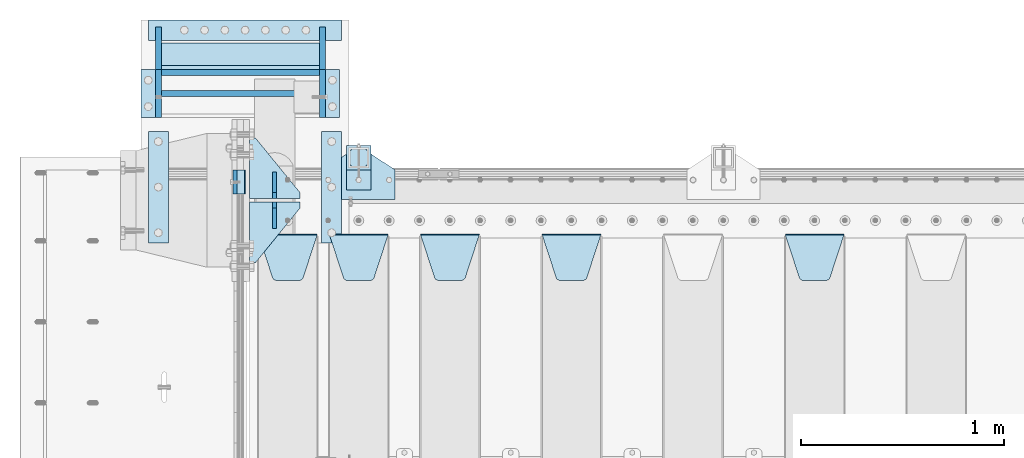
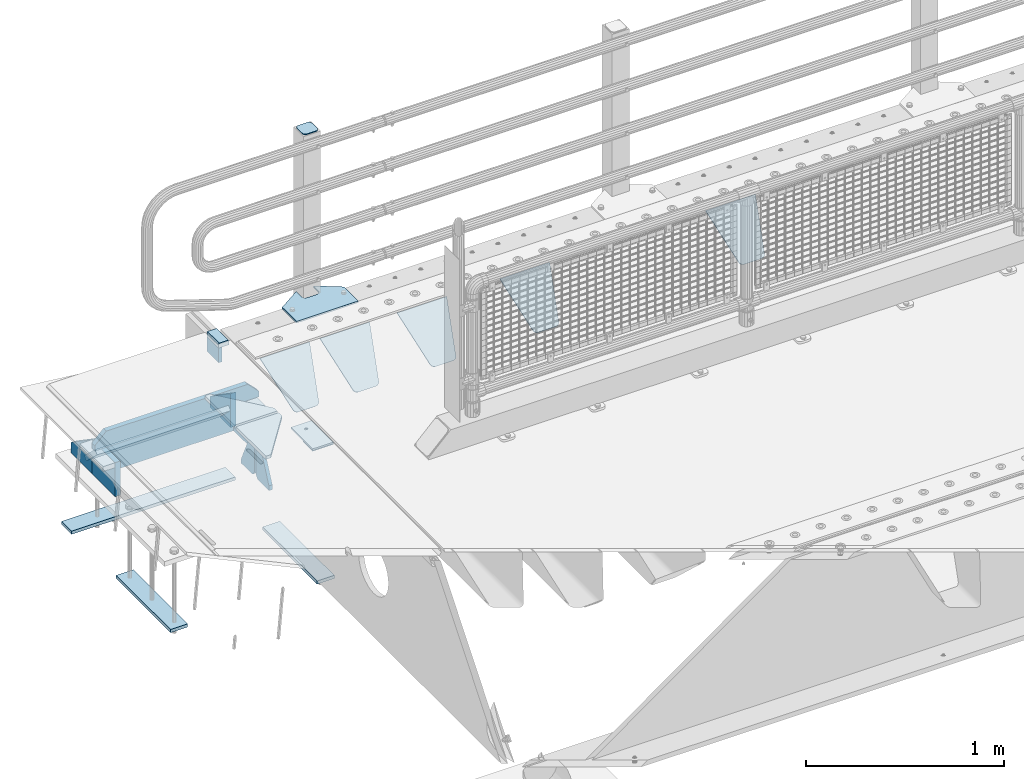
# One storey, part 171 of 208: 27 plates.
"""IFC2X3 building model written with IfcOpenShell, lengths in millimetres."""

import ifcopenshell
import ifcopenshell.guid

model = None  # the IFC model being written
_history = None  # IfcOwnerHistory: only IFC2X3 demands one
_inside = {}  # id of a spatial element -> (the spatial element, [elements in it])
_under = {}  # id of a project, library or spatial element -> (it, [spatial elements below it])
_declared = {}  # id of a project -> (the project, [libraries it declares])
_typed = {}  # id of a type object -> (the type object, [elements of that type])
_made_of = {}  # id of a material, layer set ... -> (it, [elements and type objects made of it])


def new_model(schema):
    """Start an empty IFC model of exactly this schema.

    Asked for "IFC4X3", IfcOpenShell would pick the latest addendum, in which some entities
    have other attributes; the version numbers below select the first issue.
    IFC2X3 requires an IfcOwnerHistory on every rooted entity: one is made here for all.
    """
    global model, _history
    if schema == "IFC4X3":
        model = ifcopenshell.file(schema_version=(4, 3, 0, 0))
    else:
        model = ifcopenshell.file(schema=schema)
    _inside.clear()
    _under.clear()
    _declared.clear()
    _typed.clear()
    _made_of.clear()
    _history = None
    if model.schema == "IFC2X3":
        org = make("IfcOrganization", Name="unknown")
        user = make(
            "IfcPersonAndOrganization",
            ThePerson=make("IfcPerson", FamilyName="unknown"),
            TheOrganization=org,
        )
        app = make(
            "IfcApplication",
            ApplicationDeveloper=org,
            Version="unknown",
            ApplicationFullName="unknown",
            ApplicationIdentifier="unknown",
        )
        _history = make(
            "IfcOwnerHistory",
            OwningUser=user,
            OwningApplication=app,
            ChangeAction="ADDED",
            CreationDate=0,
        )
    return model


def make(cls, **values):
    """One entity of the class cls with the attributes given. An attribute that is None is left unset."""
    return model.create_entity(
        cls, **{name: value for name, value in values.items() if value is not None}
    )


def rooted(cls, **values):
    """An entity with a GlobalId (a new one), such as an element, a storey or a relation."""
    return make(cls, GlobalId=ifcopenshell.guid.new(), OwnerHistory=_history, **values)


def si_unit(unit_type, name, prefix=None):
    """IfcSIUnit, for example si_unit("LENGTHUNIT", "METRE", prefix="MILLI")."""
    return make("IfcSIUnit", UnitType=unit_type, Prefix=prefix, Name=name)


def assignment(units):
    """IfcUnitAssignment: the units of a project."""
    return None if units is None else make("IfcUnitAssignment", Units=units)


def point(xyz):
    """IfcCartesianPoint."""
    return None if xyz is None else make("IfcCartesianPoint", Coordinates=xyz)


def direction(xyz):
    """IfcDirection."""
    return None if xyz is None else make("IfcDirection", DirectionRatios=xyz)


def frame(location, z_axis=None, x_axis=None):
    """IfcAxis2Placement3D, a coordinate frame: its origin and axes. An axis left out is left unset."""
    return make(
        "IfcAxis2Placement3D",
        Location=point(location),
        Axis=direction(z_axis),
        RefDirection=direction(x_axis),
    )


def origin_with_axes():
    """The frame at (0, 0, 0) with the z axis (0, 0, 1) and the x axis (1, 0, 0) written out."""
    return frame((0.0, 0.0, 0.0), z_axis=(0.0, 0.0, 1.0), x_axis=(1.0, 0.0, 0.0))


def place(relative_to, where):
    """IfcLocalPlacement: puts the frame where relative to a parent placement (None: the world)."""
    return make(
        "IfcLocalPlacement", PlacementRelTo=relative_to, RelativePlacement=where
    )


def context(
    kind, dimensions, precision=None, world=None, true_north=None, identifier=None
):
    """IfcGeometricRepresentationContext, for example the 3D "Model" context."""
    return make(
        "IfcGeometricRepresentationContext",
        ContextIdentifier=identifier,
        ContextType=kind,
        CoordinateSpaceDimension=dimensions,
        Precision=precision,
        WorldCoordinateSystem=world,
        TrueNorth=true_north,
    )


def subcontext(parent, identifier, kind, view, scale=None):
    """IfcGeometricRepresentationSubContext, for example "Body" below "Model"."""
    return make(
        "IfcGeometricRepresentationSubContext",
        ContextIdentifier=identifier,
        ContextType=kind,
        ParentContext=parent,
        TargetScale=scale,
        TargetView=view,
    )


def project(units=None, contexts=None):
    """IfcProject with its units and contexts."""
    return rooted(
        "IfcProject",
        Name="project",
        RepresentationContexts=contexts,
        UnitsInContext=assignment(units),
    )


def spatial(cls, under=None, at=None, **own):
    """A site, building, storey or space (cls), placed at a placement, below another one or the project."""
    s = rooted(cls, ObjectPlacement=at, **own)
    if under is not None:
        _under.setdefault(under.id(), (under, []))[1].append(s)
    return s


def faces_of(points, faces, orient=None, outer=None):
    """IfcFace entities. A face is a list of loops; a loop is a list of indices into points, from 0.

    orient and outer hold one flag for each loop. By default every Orientation is true, the
    first loop of a face is its IfcFaceOuterBound and the others are IfcFaceBound.
    """
    made = []
    for i, loops in enumerate(faces):
        bounds = []
        for j, loop in enumerate(loops):
            is_outer = j == 0 if outer is None else outer[i][j]
            bounds.append(
                make(
                    "IfcFaceOuterBound" if is_outer else "IfcFaceBound",
                    Bound=make("IfcPolyLoop", Polygon=[points[k] for k in loop]),
                    Orientation=True if orient is None else orient[i][j],
                )
            )
        made.append(make("IfcFace", Bounds=bounds))
    return made


def faceted_brep(points, faces, orient=None, outer=None, voids=None):
    """IfcFacetedBrep: a solid bounded by flat faces; with voids (closed shells), ...WithVoids."""
    shared = [point(p) for p in points]
    hull = make("IfcClosedShell", CfsFaces=faces_of(shared, faces, orient, outer))
    if voids is None:
        return make("IfcFacetedBrep", Outer=hull)
    return make(
        "IfcFacetedBrepWithVoids",
        Outer=hull,
        Voids=[
            make(cls, CfsFaces=faces_of(shared, fs, o, b)) for cls, fs, o, b in voids
        ],
    )


def shape(context_of_items, identifier, shape_type, items):
    """IfcShapeRepresentation: the items that make up one representation, for example the "Body"."""
    return make(
        "IfcShapeRepresentation",
        ContextOfItems=context_of_items,
        RepresentationIdentifier=identifier,
        RepresentationType=shape_type,
        Items=items,
    )


def material(Name=None, Category=None):
    """IfcMaterial."""
    return make("IfcMaterial", Name=Name, Category=Category)


def made_of(thing, what):
    """Note that an element or type object is made of a material, layer set ...; save() writes the relation."""
    if what is not None:
        _made_of.setdefault(what.id(), (what, []))[1].append(thing)
    return thing


def type_object(cls, material=None, **own):
    """A type object (cls), such as IfcWallType, which elements share."""
    return made_of(rooted(cls, **own), material)


def element(
    cls,
    number,
    at=None,
    inside=None,
    cuts=None,
    type_object=None,
    material=None,
    context=None,
    identifier="Body",
    shape_type=None,
    held_by="IfcProductDefinitionShape",
    body=None,
    shapes=None,
    **own,
):
    """One element of the class cls, such as IfcWall. Its Tag is "e" and its number.

    at: its placement. inside: the storey or other place that contains it. cuts: it is an
    opening in that element (IfcRelVoidsElement). A single representation is given by context,
    identifier, shape_type and body (its items); several are given by shapes. held_by: the class
    of the entity that holds the representations. save() writes the other relations.
    """
    e = rooted(cls, Tag="e%d" % number, ObjectPlacement=at, **own)
    if body is not None:
        shapes = [shape(context, identifier, shape_type, body)]
    if shapes is not None:
        e.Representation = make(held_by, Representations=shapes)
    if inside is not None:
        _inside.setdefault(inside.id(), (inside, []))[1].append(e)
    if cuts is not None:
        rooted(
            "IfcRelVoidsElement", RelatingBuildingElement=cuts, RelatedOpeningElement=e
        )
    if type_object is not None:
        _typed.setdefault(type_object.id(), (type_object, []))[1].append(e)
    return made_of(e, material)


def aggregate(whole, parts):
    """IfcRelAggregates: a whole, such as a stair, and the parts it consists of."""
    return rooted("IfcRelAggregates", RelatingObject=whole, RelatedObjects=parts)


def save(model, path):
    """Write the relations noted so far, then the file.

    IfcRelAggregates (storeys below a building ...), IfcRelContainedInSpatialStructure (elements
    in a storey), IfcRelDefinesByType, IfcRelAssociatesMaterial and IfcRelDeclares: one each for
    every whole, place, type object, material and project.
    """
    for whole, parts in _under.values():
        aggregate(whole, parts)
    for where, things in _inside.values():
        rooted(
            "IfcRelContainedInSpatialStructure",
            RelatedElements=things,
            RelatingStructure=where,
        )
    for kind, things in _typed.values():
        rooted("IfcRelDefinesByType", RelatedObjects=things, RelatingType=kind)
    for what, things in _made_of.values():
        rooted("IfcRelAssociatesMaterial", RelatedObjects=things, RelatingMaterial=what)
    for by, libraries in _declared.values():
        rooted("IfcRelDeclares", RelatingContext=by, RelatedDefinitions=libraries)
    model.write(path)


model = new_model("IFC2X3")

# Units and contexts
model_context = context("Model", 3, precision=1e-05, world=origin_with_axes())
body_context = subcontext(model_context, "Body", "Model", "MODEL_VIEW")
ifc_project = project(units=[si_unit("LENGTHUNIT", "METRE", prefix="MILLI"), si_unit("AREAUNIT", "SQUARE_METRE"), si_unit("VOLUMEUNIT", "CUBIC_METRE"), si_unit("MASSUNIT", "GRAM", prefix="KILO"), si_unit("TIMEUNIT", "SECOND"), si_unit("PLANEANGLEUNIT", "RADIAN"), si_unit("SOLIDANGLEUNIT", "STERADIAN"), si_unit("THERMODYNAMICTEMPERATUREUNIT", "DEGREE_CELSIUS"), si_unit("LUMINOUSINTENSITYUNIT", "LUMEN")], contexts=[model_context])

# Site, building, storey
site_placement = place(None, origin_with_axes())
site = spatial("IfcSite", under=ifc_project, at=site_placement, CompositionType="ELEMENT")
building_placement = place(site_placement, origin_with_axes())
building = spatial("IfcBuilding", under=site, at=building_placement, Name="Standard", CompositionType="ELEMENT")
storey_placement = place(building_placement, origin_with_axes())
storey = spatial("IfcBuildingStorey", under=building, at=storey_placement, Name="Undefined", CompositionType="ELEMENT", Elevation=0.0)

# Plates
ifc_material_1 = material()
plate_type_1 = type_object("IfcPlateType", PredefinedType="NOTDEFINED")
plate_1_placement = place(storey_placement, frame((-42460.0, 6090.0, -16.0000571414005), z_axis=(-1.0, 0.0, 0.0), x_axis=(0.0, 0.0, 1.0)))
element("IfcPlate", 1, at=plate_1_placement, inside=storey, type_object=plate_type_1, material=ifc_material_1, context=body_context, shape_type="Brep", body=[
    faceted_brep([(-1.77635683940025e-15, -60.0, 0.0), (2.49929144047201e-09, -59.9999999999995, 60.0), (2.49929144047201e-09, 60.0000000000005, 60.0), (-1.77635683940025e-15, 60.0, -7.27595761418343e-12), (25.0146748218828, -59.9999999999995, 60.0), (25.0146748218828, 60.0, 60.0), (26.5597449794466, -59.9999999999995, 59.7552873949098), (26.5597449794466, 60.0000000000005, 59.7552873949098), (27.9535758796897, -59.9999999999995, 59.0451032832789), (27.9535758796897, 60.0000000000005, 59.0451032832789), (29.0597323263517, -59.9999999999995, 57.9389640667287), (29.0597323263517, 60.0, 57.9389640667287), (29.7699381491534, -59.9999999999995, 56.5451442289705), (29.7699381491534, 60.0000000000005, 56.5451442289705), (30.0146748212763, -59.9999999999995, 55.0000778834001), (30.0146748212763, 60.0000000000005, 55.0000778834001), (30.0154536553013, -59.9999999999995, 5.00007788340736), (30.0154536553013, 60.0000000000005, 5.00007788340736), (29.7707554908505, -59.9999999999995, 3.45497428546514), (29.7707554908505, 60.0000000000005, 3.45497428546514), (29.0605660948355, -59.9999999999995, 2.06111154406972), (29.0605660948355, 60.0000000000005, 2.06111154406972), (27.9544051209123, -59.9999999999995, 0.954933339693525), (27.9544051209123, 60.0000000000005, 0.954933339693525), (26.5605534420796, -59.9999999999995, 0.244722232011554), (26.5605534420796, 60.0000000000005, 0.244722232011554), (25.0154536559091, -59.9999999999991, 7.27595761418343e-12), (25.0154536559091, 60.0000000000005, 7.27595761418343e-12)], [[[0, 1, 2, 3]], [[1, 4, 5, 2]], [[4, 6, 7, 5]], [[6, 8, 9, 7]], [[8, 10, 11, 9]], [[10, 12, 13, 11]], [[12, 14, 15, 13]], [[14, 16, 17, 15]], [[16, 18, 19, 17]], [[18, 20, 21, 19]], [[20, 22, 23, 21]], [[22, 24, 25, 23]], [[24, 26, 27, 25]], [[26, 0, 3, 27]], [[5, 7, 9, 11, 13, 15, 17, 19, 21, 23, 25, 27, 3, 2]], [[26, 24, 22, 20, 18, 16, 14, 12, 10, 8, 6, 4, 1, 0]]]),
])
ifc_material_2 = material(Name="STEEL/S355N")
plate_type_2 = type_object("IfcPlateType", PredefinedType="NOTDEFINED")
plate_2_placement = place(storey_placement, frame((-42510.0, 6150.00008553451, -105.984391680281), z_axis=(0.0, -1.0, 0.0), x_axis=(0.0, 0.0, 1.0)))
element("IfcPlate", 2, at=plate_2_placement, inside=storey, type_object=plate_type_2, material=ifc_material_2, context=body_context, shape_type="Brep", body=[
    faceted_brep([(0.0, -10.0, 0.0), (5.7072624315424e-07, -10.0, 120.0), (5.7072624315424e-07, 10.0, 120.0), (0.0, 10.0, 0.0), (89.9845046997072, -10.0, 120.0), (89.9845046997072, 10.0, 120.0), (89.9843902587891, -10.0, 6.54836185276508e-11), (89.9843902587891, 10.0, 6.54836185276508e-11)], [[[0, 1, 2, 3]], [[1, 4, 5, 2]], [[4, 6, 7, 5]], [[6, 0, 3, 7]], [[5, 7, 3, 2]], [[6, 4, 1, 0]]]),
])
plate_type_3 = type_object("IfcPlateType", PredefinedType="NOTDEFINED")
plate_3_placement = place(storey_placement, frame((-39795.0, 5831.76776695596, -1.76776695296758), z_axis=(0.0, -0.707106781186548, -0.707106781186547), x_axis=(1.0, 0.0, 0.0)))
element("IfcPlate", 3, at=plate_3_placement, inside=storey, type_object=plate_type_3, material=ifc_material_2, context=body_context, shape_type="Brep", body=[
    faceted_brep([(0.0, -2.5, 0.0), (69.345504679477, -2.5, 300.17173142483), (69.345504679477, 2.5, 300.17173142483), (0.0, 2.5, 0.0), (70.9274061199576, -2.5, 304.897442415399), (70.9274061199576, 2.5, 304.8974424154), (73.3818627772307, -2.5, 309.234538108527), (73.3818627772307, 2.5, 309.234538108527), (76.6187032999551, -2.5, 313.023683126103), (76.6187032999551, 2.5, 313.023683126103), (80.5190132704993, -2.5, 316.125672595371), (80.5190132704993, 2.5, 316.125672595371), (84.9395038596849, -2.5, 318.426546230476), (84.9395038596849, 2.50000000000091, 318.426546230476), (89.7177759439219, -2.5, 319.841774983275), (89.7177759439219, 2.50000000000091, 319.841774983275), (94.678286292652, -2.49999999999909, 320.319366455078), (94.678286292652, 2.5, 320.319366455078), (195.321713707348, -2.49999999999909, 320.319366455078), (195.321713707348, 2.5, 320.319366455078), (200.282224056078, -2.5, 319.841774983275), (200.282224056078, 2.5, 319.841774983274), (205.060496140315, -2.5, 318.426546230475), (205.060496140315, 2.5, 318.426546230475), (209.480986729501, -2.5, 316.125672595371), (209.480986729501, 2.50000000000091, 316.125672595371), (213.381296700045, -2.5, 313.023683126102), (213.381296700045, 2.5, 313.023683126102), (216.618137222769, -2.5, 309.234538108526), (216.618137222769, 2.5, 309.234538108527), (219.072593880042, -2.5, 304.897442415399), (219.072593880042, 2.5, 304.897442415399), (220.654495320523, -2.5, 300.17173142483), (220.654495320523, 2.5, 300.17173142483), (290.0, -2.5, 0.0), (290.0, 2.5, 0.0)], [[[0, 1, 2, 3]], [[1, 4, 5, 2]], [[4, 6, 7, 5]], [[6, 8, 9, 7]], [[8, 10, 11, 9]], [[10, 12, 13, 11]], [[12, 14, 15, 13]], [[14, 16, 17, 15]], [[16, 18, 19, 17]], [[18, 20, 21, 19]], [[20, 22, 23, 21]], [[22, 24, 25, 23]], [[24, 26, 27, 25]], [[26, 28, 29, 27]], [[28, 30, 31, 29]], [[30, 32, 33, 31]], [[32, 34, 35, 33]], [[34, 0, 3, 35]], [[5, 7, 9, 11, 13, 15, 17, 19, 21, 23, 25, 27, 29, 31, 33, 35, 3, 2]], [[34, 32, 30, 28, 26, 24, 22, 20, 18, 16, 14, 12, 10, 8, 6, 4, 1, 0]]]),
])
plate_4_placement = place(storey_placement, frame((-40995.0, 5831.76776695596, -1.76776695296758), z_axis=(0.0, -0.707106781186548, -0.707106781186547), x_axis=(1.0, 0.0, 0.0)))
element("IfcPlate", 4, at=plate_4_placement, inside=storey, type_object=plate_type_3, material=ifc_material_2, context=body_context, shape_type="Brep", body=[
    faceted_brep([(0.0, -2.5, 0.0), (69.345504679477, -2.5, 300.17173142483), (69.345504679477, 2.5, 300.17173142483), (0.0, 2.5, 0.0), (70.9274061199576, -2.5, 304.897442415399), (70.9274061199576, 2.5, 304.8974424154), (73.3818627772307, -2.5, 309.234538108527), (73.3818627772307, 2.5, 309.234538108527), (76.6187032999551, -2.5, 313.023683126103), (76.6187032999551, 2.5, 313.023683126103), (80.5190132704993, -2.5, 316.125672595371), (80.5190132704993, 2.5, 316.125672595371), (84.9395038596849, -2.5, 318.426546230476), (84.9395038596849, 2.50000000000091, 318.426546230476), (89.7177759439219, -2.5, 319.841774983275), (89.7177759439219, 2.50000000000091, 319.841774983275), (94.678286292652, -2.49999999999909, 320.319366455078), (94.678286292652, 2.5, 320.319366455078), (195.321713707348, -2.49999999999909, 320.319366455078), (195.321713707348, 2.5, 320.319366455078), (200.282224056078, -2.5, 319.841774983275), (200.282224056078, 2.5, 319.841774983274), (205.060496140315, -2.5, 318.426546230475), (205.060496140315, 2.5, 318.426546230475), (209.480986729501, -2.5, 316.125672595371), (209.480986729501, 2.50000000000091, 316.125672595371), (213.381296700045, -2.5, 313.023683126102), (213.381296700045, 2.5, 313.023683126102), (216.618137222769, -2.5, 309.234538108526), (216.618137222769, 2.5, 309.234538108527), (219.072593880042, -2.5, 304.897442415399), (219.072593880042, 2.5, 304.897442415399), (220.654495320523, -2.5, 300.17173142483), (220.654495320523, 2.5, 300.17173142483), (290.0, -2.5, 0.0), (290.0, 2.5, 0.0)], [[[0, 1, 2, 3]], [[1, 4, 5, 2]], [[4, 6, 7, 5]], [[6, 8, 9, 7]], [[8, 10, 11, 9]], [[10, 12, 13, 11]], [[12, 14, 15, 13]], [[14, 16, 17, 15]], [[16, 18, 19, 17]], [[18, 20, 21, 19]], [[20, 22, 23, 21]], [[22, 24, 25, 23]], [[24, 26, 27, 25]], [[26, 28, 29, 27]], [[28, 30, 31, 29]], [[30, 32, 33, 31]], [[32, 34, 35, 33]], [[34, 0, 3, 35]], [[5, 7, 9, 11, 13, 15, 17, 19, 21, 23, 25, 27, 29, 31, 33, 35, 3, 2]], [[34, 32, 30, 28, 26, 24, 22, 20, 18, 16, 14, 12, 10, 8, 6, 4, 1, 0]]]),
])
plate_5_placement = place(storey_placement, frame((-41595.0, 5831.76776695596, -1.76776695296758), z_axis=(0.0, -0.707106781186548, -0.707106781186547), x_axis=(1.0, 0.0, 0.0)))
element("IfcPlate", 5, at=plate_5_placement, inside=storey, type_object=plate_type_3, material=ifc_material_2, context=body_context, shape_type="Brep", body=[
    faceted_brep([(0.0, -2.5, 0.0), (69.345504679477, -2.5, 300.17173142483), (69.345504679477, 2.5, 300.17173142483), (0.0, 2.5, 0.0), (70.9274061199576, -2.5, 304.897442415399), (70.9274061199576, 2.5, 304.8974424154), (73.3818627772307, -2.5, 309.234538108527), (73.3818627772307, 2.5, 309.234538108527), (76.6187032999551, -2.5, 313.023683126103), (76.6187032999551, 2.5, 313.023683126103), (80.5190132704993, -2.5, 316.125672595371), (80.5190132704993, 2.5, 316.125672595371), (84.9395038596849, -2.5, 318.426546230476), (84.9395038596849, 2.50000000000091, 318.426546230476), (89.7177759439219, -2.5, 319.841774983275), (89.7177759439219, 2.50000000000091, 319.841774983275), (94.678286292652, -2.49999999999909, 320.319366455078), (94.678286292652, 2.5, 320.319366455078), (195.321713707348, -2.49999999999909, 320.319366455078), (195.321713707348, 2.5, 320.319366455078), (200.282224056078, -2.5, 319.841774983275), (200.282224056078, 2.5, 319.841774983274), (205.060496140315, -2.5, 318.426546230475), (205.060496140315, 2.5, 318.426546230475), (209.480986729501, -2.5, 316.125672595371), (209.480986729501, 2.50000000000091, 316.125672595371), (213.381296700045, -2.5, 313.023683126102), (213.381296700045, 2.5, 313.023683126102), (216.618137222769, -2.5, 309.234538108526), (216.618137222769, 2.5, 309.234538108527), (219.072593880042, -2.5, 304.897442415399), (219.072593880042, 2.5, 304.897442415399), (220.654495320523, -2.5, 300.17173142483), (220.654495320523, 2.5, 300.17173142483), (290.0, -2.5, 0.0), (290.0, 2.5, 0.0)], [[[0, 1, 2, 3]], [[1, 4, 5, 2]], [[4, 6, 7, 5]], [[6, 8, 9, 7]], [[8, 10, 11, 9]], [[10, 12, 13, 11]], [[12, 14, 15, 13]], [[14, 16, 17, 15]], [[16, 18, 19, 17]], [[18, 20, 21, 19]], [[20, 22, 23, 21]], [[22, 24, 25, 23]], [[24, 26, 27, 25]], [[26, 28, 29, 27]], [[28, 30, 31, 29]], [[30, 32, 33, 31]], [[32, 34, 35, 33]], [[34, 0, 3, 35]], [[5, 7, 9, 11, 13, 15, 17, 19, 21, 23, 25, 27, 29, 31, 33, 35, 3, 2]], [[34, 32, 30, 28, 26, 24, 22, 20, 18, 16, 14, 12, 10, 8, 6, 4, 1, 0]]]),
])
plate_6_placement = place(storey_placement, frame((-42045.0, 5831.76776695596, -1.76776695296758), z_axis=(0.0, -0.707106781186548, -0.707106781186547), x_axis=(1.0, 0.0, 0.0)))
element("IfcPlate", 6, at=plate_6_placement, inside=storey, type_object=plate_type_3, material=ifc_material_2, context=body_context, shape_type="Brep", body=[
    faceted_brep([(0.0, -2.5, 0.0), (69.345504679477, -2.5, 300.17173142483), (69.345504679477, 2.5, 300.17173142483), (0.0, 2.5, 0.0), (70.9274061199576, -2.5, 304.897442415399), (70.9274061199576, 2.5, 304.8974424154), (73.3818627772307, -2.5, 309.234538108527), (73.3818627772307, 2.5, 309.234538108527), (76.6187032999551, -2.5, 313.023683126103), (76.6187032999551, 2.5, 313.023683126103), (80.5190132704993, -2.5, 316.125672595371), (80.5190132704993, 2.5, 316.125672595371), (84.9395038596849, -2.5, 318.426546230476), (84.9395038596849, 2.50000000000091, 318.426546230476), (89.7177759439219, -2.5, 319.841774983275), (89.7177759439219, 2.50000000000091, 319.841774983275), (94.678286292652, -2.49999999999909, 320.319366455078), (94.678286292652, 2.5, 320.319366455078), (195.321713707348, -2.49999999999909, 320.319366455078), (195.321713707348, 2.5, 320.319366455078), (200.282224056078, -2.5, 319.841774983275), (200.282224056078, 2.5, 319.841774983274), (205.060496140315, -2.5, 318.426546230475), (205.060496140315, 2.5, 318.426546230475), (209.480986729501, -2.5, 316.125672595371), (209.480986729501, 2.50000000000091, 316.125672595371), (213.381296700045, -2.5, 313.023683126102), (213.381296700045, 2.5, 313.023683126102), (216.618137222769, -2.5, 309.234538108526), (216.618137222769, 2.5, 309.234538108527), (219.072593880042, -2.5, 304.897442415399), (219.072593880042, 2.5, 304.897442415399), (220.654495320523, -2.5, 300.17173142483), (220.654495320523, 2.5, 300.17173142483), (290.0, -2.5, 0.0), (290.0, 2.5, 0.0)], [[[0, 1, 2, 3]], [[1, 4, 5, 2]], [[4, 6, 7, 5]], [[6, 8, 9, 7]], [[8, 10, 11, 9]], [[10, 12, 13, 11]], [[12, 14, 15, 13]], [[14, 16, 17, 15]], [[16, 18, 19, 17]], [[18, 20, 21, 19]], [[20, 22, 23, 21]], [[22, 24, 25, 23]], [[24, 26, 27, 25]], [[26, 28, 29, 27]], [[28, 30, 31, 29]], [[30, 32, 33, 31]], [[32, 34, 35, 33]], [[34, 0, 3, 35]], [[5, 7, 9, 11, 13, 15, 17, 19, 21, 23, 25, 27, 29, 31, 33, 35, 3, 2]], [[34, 32, 30, 28, 26, 24, 22, 20, 18, 16, 14, 12, 10, 8, 6, 4, 1, 0]]]),
])
plate_7_placement = place(storey_placement, frame((-42395.0, 5831.76776695596, -1.76776695296758), z_axis=(0.0, -0.707106781186548, -0.707106781186547), x_axis=(1.0, 0.0, 0.0)))
element("IfcPlate", 7, at=plate_7_placement, inside=storey, type_object=plate_type_3, material=ifc_material_2, context=body_context, shape_type="Brep", body=[
    faceted_brep([(0.0, -2.5, 0.0), (69.345504679477, -2.5, 300.17173142483), (69.345504679477, 2.5, 300.17173142483), (0.0, 2.5, 0.0), (70.9274061199576, -2.5, 304.897442415399), (70.9274061199576, 2.5, 304.8974424154), (73.3818627772307, -2.5, 309.234538108527), (73.3818627772307, 2.5, 309.234538108527), (76.6187032999551, -2.5, 313.023683126103), (76.6187032999551, 2.5, 313.023683126103), (80.5190132704993, -2.5, 316.125672595371), (80.5190132704993, 2.5, 316.125672595371), (84.9395038596849, -2.5, 318.426546230476), (84.9395038596849, 2.50000000000091, 318.426546230476), (89.7177759439219, -2.5, 319.841774983275), (89.7177759439219, 2.50000000000091, 319.841774983275), (94.678286292652, -2.49999999999909, 320.319366455078), (94.678286292652, 2.5, 320.319366455078), (195.321713707348, -2.49999999999909, 320.319366455078), (195.321713707348, 2.5, 320.319366455078), (200.282224056078, -2.5, 319.841774983275), (200.282224056078, 2.5, 319.841774983274), (205.060496140315, -2.5, 318.426546230475), (205.060496140315, 2.5, 318.426546230475), (209.480986729501, -2.5, 316.125672595371), (209.480986729501, 2.50000000000091, 316.125672595371), (213.381296700045, -2.5, 313.023683126102), (213.381296700045, 2.5, 313.023683126102), (216.618137222769, -2.5, 309.234538108526), (216.618137222769, 2.5, 309.234538108527), (219.072593880042, -2.5, 304.897442415399), (219.072593880042, 2.5, 304.897442415399), (220.654495320523, -2.5, 300.17173142483), (220.654495320523, 2.5, 300.17173142483), (290.0, -2.5, 0.0), (290.0, 2.5, 0.0)], [[[0, 1, 2, 3]], [[1, 4, 5, 2]], [[4, 6, 7, 5]], [[6, 8, 9, 7]], [[8, 10, 11, 9]], [[10, 12, 13, 11]], [[12, 14, 15, 13]], [[14, 16, 17, 15]], [[16, 18, 19, 17]], [[18, 20, 21, 19]], [[20, 22, 23, 21]], [[22, 24, 25, 23]], [[24, 26, 27, 25]], [[26, 28, 29, 27]], [[28, 30, 31, 29]], [[30, 32, 33, 31]], [[32, 34, 35, 33]], [[34, 0, 3, 35]], [[5, 7, 9, 11, 13, 15, 17, 19, 21, 23, 25, 27, 29, 31, 33, 35, 3, 2]], [[34, 32, 30, 28, 26, 24, 22, 20, 18, 16, 14, 12, 10, 8, 6, 4, 1, 0]]]),
])
plate_type_4 = type_object("IfcPlateType", PredefinedType="NOTDEFINED")
for number, where, z_axis, x_axis in (
    (8, (-42190.0, 6008.0, -515.0), (0.0, 1.0, 0.0), (-1.0, 0.0, 0.0)),
    (9, (-42190.0, 5992.0, -515.0), (0.0, -1.0, 0.0), (-1.0, 0.0, 0.0)),
):
    element("IfcPlate", number, at=place(storey_placement, frame(where, z_axis=z_axis, x_axis=x_axis)), inside=storey, type_object=plate_type_4, material=ifc_material_2, context=body_context, shape_type="Brep", body=[
        faceted_brep([(0.0, -10.0, 0.0), (0.0, -10.0, 30.0), (0.0, 10.0, 30.0), (0.0, 10.0, 0.0), (220.0, -10.0, 300.0), (220.0, 10.0, 300.0), (250.0, -10.0, 300.0), (250.0, 10.0, 300.0), (250.0, -10.0, 0.0), (250.0, 10.0, 0.0)], [[[0, 1, 2, 3]], [[1, 4, 5, 2]], [[4, 6, 7, 5]], [[6, 8, 9, 7]], [[8, 0, 3, 9]], [[5, 7, 9, 3, 2]], [[8, 6, 4, 1, 0]]]),
    ])
plate_type_5 = type_object("IfcPlateType", PredefinedType="NOTDEFINED")
for number, where, z_axis, x_axis in (
    (10, (-42315.0, 6140.0, -860.0), (0.0, 0.0, 1.0), (0.0, -1.0, 0.0)),
    (11, (-42315.0, 5860.0, -860.0), (0.0, 0.0, 1.0), (0.0, 1.0, 0.0)),
):
    element("IfcPlate", number, at=place(storey_placement, frame(where, z_axis=z_axis, x_axis=x_axis)), inside=storey, type_object=plate_type_5, material=ifc_material_2, context=body_context, shape_type="Brep", body=[
        faceted_brep([(0.0, -10.0, 0.0), (0.0, -10.0, 30.0), (0.0, 10.0, 30.0), (0.0, 10.0, 0.0), (102.0, -10.0, 250.0), (102.0, 10.0, 250.0), (132.0, -10.0, 250.0), (132.0, 10.0, 250.0), (132.0, -10.0, 30.0), (132.0, 10.0, 30.0), (131.544232590366, -10.0, 24.790554669992), (131.544232590366, 10.0, 24.790554669992), (130.190778623577, -10.0, 19.7393957002299), (130.190778623577, 10.0, 19.7393957002299), (127.980762113533, -10.0, 15.0), (127.980762113533, 10.0, 15.0), (124.981333293569, -10.0, 10.7163717094038), (124.981333293569, 10.0, 10.7163717094038), (121.283628290596, -10.0, 7.01866670643062), (121.283628290596, 10.0, 7.01866670643062), (117.0, -10.0, 4.01923788646684), (117.0, 10.0, 4.01923788646684), (112.26060429977, -10.0, 1.80922137642278), (112.26060429977, 10.0, 1.80922137642278), (107.209445330008, -10.0, 0.455767409633722), (107.209445330008, 10.0, 0.455767409633722), (102.0, -10.0, 0.0), (102.0, 10.0, 0.0)], [[[0, 1, 2, 3]], [[1, 4, 5, 2]], [[4, 6, 7, 5]], [[6, 8, 9, 7]], [[8, 10, 11, 9]], [[10, 12, 13, 11]], [[12, 14, 15, 13]], [[14, 16, 17, 15]], [[16, 18, 19, 17]], [[18, 20, 21, 19]], [[20, 22, 23, 21]], [[22, 24, 25, 23]], [[24, 26, 27, 25]], [[26, 0, 3, 27]], [[5, 7, 9, 11, 13, 15, 17, 19, 21, 23, 25, 27, 3, 2]], [[26, 24, 22, 20, 18, 16, 14, 12, 10, 8, 6, 4, 1, 0]]]),
    ])
ifc_material_3 = material(Name="STEEL/S355J2")
plate_type_6 = type_object("IfcPlateType", PredefinedType="NOTDEFINED")
plate_8_placement = place(storey_placement, frame((-42080.0, 6005.0, 5.00000000004911), z_axis=(0.0, 1.0, 0.0), x_axis=(1.0, 0.0, 0.0)))
element("IfcPlate", 12, at=plate_8_placement, inside=storey, type_object=plate_type_6, material=ifc_material_3, context=body_context, shape_type="Brep", body=[
    faceted_brep([(0.0, -5.0, 0.0), (2.31396552408114e-06, -5.0, 145.0), (2.31396552408114e-06, 5.0, 145.0), (0.0, 5.0, 0.0), (130.0, -5.0, 230.0), (130.0, 5.0, 230.0), (130.0, -5.0, 180.0), (130.0, 5.0, 180.0), (130.48036798992, -5.0, 175.122741949597), (130.48036798992, 5.0, 175.122741949597), (131.903011687216, -5.0, 170.432914190873), (131.903011687216, 5.0, 170.432914190873), (134.213259692435, -5.0, 166.11074417451), (134.213259692435, 5.0, 166.11074417451), (137.322330470335, -5.0, 162.322330470336), (137.322330470335, 5.0, 162.322330470336), (141.110744174512, -5.0, 159.213259692437), (141.110744174512, 5.0, 159.213259692437), (145.432914190871, -5.0, 156.903011687218), (145.432914190871, 5.0, 156.903011687218), (150.122741949595, -5.0, 155.48036798992), (150.122741949595, 5.0, 155.48036798992), (155.0, -5.0, 155.0), (155.0, 5.0, 155.0), (205.0, -5.0, 155.0), (205.0, 5.0, 155.0), (209.877258050405, -5.0, 155.48036798992), (209.877258050405, 5.0, 155.48036798992), (214.567085809129, -5.0, 156.903011687218), (214.567085809129, 5.0, 156.903011687218), (218.889255825488, -5.0, 159.213259692437), (218.889255825488, 5.0, 159.213259692437), (222.677669529665, -5.0, 162.322330470336), (222.677669529665, 5.0, 162.322330470336), (225.786740307565, -5.0, 166.11074417451), (225.786740307565, 5.0, 166.11074417451), (228.096988312784, -5.0, 170.432914190873), (228.096988312784, 5.0, 170.432914190873), (229.51963201008, -5.0, 175.122741949597), (229.51963201008, 5.0, 175.122741949597), (230.0, -5.0, 180.0), (230.0, 5.0, 180.0), (230.0, -5.0, 230.0), (230.0, 5.0, 230.0), (360.0, -5.0, 145.0), (360.0, 5.0, 145.0), (360.0, -5.0, -7.27595761418343e-12), (360.0, 5.0, -7.27595761418343e-12)], [[[0, 1, 2, 3]], [[1, 4, 5, 2]], [[4, 6, 7, 5]], [[6, 8, 9, 7]], [[8, 10, 11, 9]], [[10, 12, 13, 11]], [[12, 14, 15, 13]], [[14, 16, 17, 15]], [[16, 18, 19, 17]], [[18, 20, 21, 19]], [[20, 22, 23, 21]], [[22, 24, 25, 23]], [[24, 26, 27, 25]], [[26, 28, 29, 27]], [[28, 30, 31, 29]], [[30, 32, 33, 31]], [[32, 34, 35, 33]], [[34, 36, 37, 35]], [[36, 38, 39, 37]], [[38, 40, 41, 39]], [[40, 42, 43, 41]], [[42, 44, 45, 43]], [[44, 46, 47, 45]], [[46, 0, 3, 47]], [[5, 7, 9, 11, 13, 15, 17, 19, 21, 23, 25, 27, 29, 31, 33, 35, 37, 39, 41, 43, 45, 47, 3, 2]], [[46, 44, 42, 40, 38, 36, 34, 32, 30, 28, 26, 24, 22, 20, 18, 16, 14, 12, 10, 8, 6, 4, 1, 0]]]),
])
plate_type_7 = type_object("IfcPlateType", PredefinedType="NOTDEFINED")
plate_9_placement = place(storey_placement, frame((-41959.9999999999, 6050.00000000021, -850.000000000002), z_axis=(0.0, 1.0, 0.0), x_axis=(1.0, 0.0, 0.0)))
element("IfcPlate", 13, at=plate_9_placement, inside=storey, type_object=plate_type_7, material=ifc_material_3, context=body_context, shape_type="Brep", body=[
    faceted_brep([(66.3639610305399, -5.0, 163.636038969112), (66.3639610305399, 5.0, 163.636038969112), (59.9999999998618, 5.0, 160.999999999791), (59.9999999998618, -5.0, 160.999999999791), (53.6360389691836, 5.0, 163.636038969112), (53.6360389691836, -5.0, 163.636038969112), (50.9999999998618, 5.0, 169.999999999791), (50.9999999998618, -5.0, 169.999999999791), (53.6360389691836, 5.0, 176.36396103047), (53.6360389691836, -5.0, 176.36396103047), (59.9999999998618, 5.0, 178.999999999791), (59.9999999998618, -5.0, 178.999999999791), (66.3639610305399, 5.0, 176.36396103047), (66.3639610305399, -5.0, 176.36396103047), (68.9999999998618, 5.0, 169.999999999791), (68.9999999998618, -5.0, 169.999999999791), (120.0, -5.0, 0.0), (120.0, -5.0, 220.0), (0.0, -5.0, 220.0), (0.0, -5.0, 0.0), (0.0, 5.0, 0.0), (120.0, 5.0, 0.0), (120.0, 5.0, 220.0), (0.0, 5.0, 220.0)], [[[0, 1, 2, 3]], [[3, 2, 4, 5]], [[5, 4, 6, 7]], [[7, 6, 8, 9]], [[9, 8, 10, 11]], [[11, 10, 12, 13]], [[13, 12, 14, 15]], [[15, 14, 1, 0]], [[16, 17, 18, 19], [3, 5, 7, 9, 11, 13, 15, 0]], [[16, 19, 20, 21]], [[17, 16, 21, 22]], [[18, 17, 22, 23]], [[19, 18, 23, 20]], [[22, 21, 20, 23], [10, 8, 6, 4, 2, 1, 14, 12]]]),
])
plate_type_8 = type_object("IfcPlateType", PredefinedType="NOTDEFINED")
plate_10_placement = place(storey_placement, frame((-41855.9999999999, 6166.00000000021, 1012.50000000001), z_axis=(0.0, 1.0, 0.0), x_axis=(-1.0, 0.0, 0.0)))
element("IfcPlate", 14, at=plate_10_placement, inside=storey, type_object=plate_type_8, material=ifc_material_3, context=body_context, shape_type="Brep", body=[
    faceted_brep([(0.0, -2.5, 19.0), (0.0, -2.5, 69.0), (0.0, 2.5, 69.0), (0.0, 2.5, 19.0), (0.476369668544066, -2.5, 73.2278977451697), (0.476369668544066, 2.5, 73.2278977451697), (1.88159150985302, -2.5, 77.2437910432336), (1.88159150985302, 2.5, 77.2437910432336), (4.14520183310742, -2.5, 80.8463062353158), (4.14520183310742, 2.5, 80.8463062353158), (7.15369376468516, -2.5, 83.8547981668926), (7.15369376468516, 2.5, 83.8547981668926), (10.7562089567655, -2.5, 86.1184084901461), (10.7562089567655, 2.5, 86.1184084901461), (14.7721022548285, -2.5, 87.523630331455), (14.7721022548285, 2.5, 87.523630331455), (19.0, -2.5, 88.0), (19.0, 2.5, 88.0), (69.0, -2.5, 88.0), (69.0, 2.5, 88.0), (73.2278977451715, -2.5, 87.523630331455), (73.2278977451715, 2.5, 87.523630331455), (77.2437910432345, -2.5, 86.1184084901461), (77.2437910432345, 2.5, 86.1184084901461), (80.8463062353148, -2.5, 83.8547981668926), (80.8463062353148, 2.5, 83.8547981668926), (83.8547981668926, -2.5, 80.8463062353158), (83.8547981668926, 2.5, 80.8463062353158), (86.118408490147, -2.5, 77.2437910432336), (86.118408490147, 2.5, 77.2437910432336), (87.5236303314559, -2.5, 73.2278977451697), (87.5236303314559, 2.5, 73.2278977451697), (88.0, -2.5, 69.0), (88.0, 2.5, 69.0), (88.0, -2.5, 19.0), (88.0, 2.5, 19.0), (87.5236303314559, -2.5, 14.7721022548303), (87.5236303314559, 2.5, 14.7721022548303), (86.118408490147, -2.5, 10.7562089567664), (86.118408490147, 2.5, 10.7562089567664), (83.8547981668926, -2.5, 7.15369376468425), (83.8547981668926, 2.5, 7.15369376468425), (80.8463062353148, -2.5, 4.14520183310742), (80.8463062353148, 2.5, 4.14520183310742), (77.2437910432345, -2.5, 1.88159150985393), (77.2437910432345, 2.5, 1.88159150985393), (73.2278977451715, -2.5, 0.476369668544976), (73.2278977451715, 2.5, 0.476369668544976), (69.0, -2.5, 0.0), (69.0, 2.5, 0.0), (19.0, -2.5, 0.0), (19.0, 2.5, 0.0), (14.7721022548285, -2.5, 0.476369668544976), (14.7721022548285, 2.5, 0.476369668544976), (10.7562089567655, -2.5, 1.88159150985393), (10.7562089567655, 2.5, 1.88159150985393), (7.15369376468516, -2.5, 4.14520183310742), (7.15369376468516, 2.5, 4.14520183310742), (4.14520183310742, -2.5, 7.15369376468425), (4.14520183310742, 2.5, 7.15369376468425), (1.88159150985302, -2.5, 10.7562089567664), (1.88159150985302, 2.5, 10.7562089567664), (0.476369668544066, -2.5, 14.7721022548303), (0.476369668544066, 2.5, 14.7721022548303)], [[[0, 1, 2, 3]], [[1, 4, 5, 2]], [[4, 6, 7, 5]], [[6, 8, 9, 7]], [[8, 10, 11, 9]], [[10, 12, 13, 11]], [[12, 14, 15, 13]], [[14, 16, 17, 15]], [[16, 18, 19, 17]], [[18, 20, 21, 19]], [[20, 22, 23, 21]], [[22, 24, 25, 23]], [[24, 26, 27, 25]], [[26, 28, 29, 27]], [[28, 30, 31, 29]], [[30, 32, 33, 31]], [[32, 34, 35, 33]], [[34, 36, 37, 35]], [[36, 38, 39, 37]], [[38, 40, 41, 39]], [[40, 42, 43, 41]], [[42, 44, 45, 43]], [[44, 46, 47, 45]], [[46, 48, 49, 47]], [[48, 50, 51, 49]], [[50, 52, 53, 51]], [[52, 54, 55, 53]], [[54, 56, 57, 55]], [[56, 58, 59, 57]], [[58, 60, 61, 59]], [[60, 62, 63, 61]], [[62, 0, 3, 63]], [[5, 7, 9, 11, 13, 15, 17, 19, 21, 23, 25, 27, 29, 31, 33, 35, 37, 39, 41, 43, 45, 47, 49, 51, 53, 55, 57, 59, 61, 63, 3, 2]], [[62, 60, 58, 56, 54, 52, 50, 48, 46, 44, 42, 40, 38, 36, 34, 32, 30, 28, 26, 24, 22, 20, 18, 16, 14, 12, 10, 8, 6, 4, 1, 0]]]),
])
plate_type_9 = type_object("IfcPlateType", PredefinedType="NOTDEFINED")
plate_11_placement = place(storey_placement, frame((-41959.9999999999, 6050.00000000021, -857.500000000002), z_axis=(0.0, 1.0, 0.0), x_axis=(1.0, 0.0, 0.0)))
element("IfcPlate", 15, at=plate_11_placement, inside=storey, type_object=plate_type_9, material=ifc_material_3, context=body_context, shape_type="Brep", body=[
    faceted_brep([(0.0, -2.5, 0.0), (0.0, -2.5, 100.0), (0.0, 2.5, 100.0), (0.0, 2.5, 0.0), (120.0, -2.5, 100.0), (120.0, 2.5, 100.0), (120.0, -2.5, 0.0), (120.0, 2.5, 0.0)], [[[0, 1, 2, 3]], [[1, 4, 5, 2]], [[4, 6, 7, 5]], [[6, 0, 3, 7]], [[5, 7, 3, 2]], [[6, 4, 1, 0]]]),
])
plate_type_10 = type_object("IfcPlateType", PredefinedType="NOTDEFINED")
plate_12_placement = place(storey_placement, frame((-42095.0, 6765.35713475324, -1017.14966545659), z_axis=(-1.0, 0.0, 0.0), x_axis=(0.0, -0.723355636225728, 0.690475650215467)))
element("IfcPlate", 16, at=plate_12_placement, inside=storey, type_object=plate_type_10, material=ifc_material_2, context=body_context, shape_type="Brep", body=[
    faceted_brep([(0.0, -15.0, 0.0), (-9.09494701772928e-13, -15.0, 779.0), (-1.81898940354586e-12, 15.0000000000009, 779.0), (0.0, 15.0, 0.0), (152.069061279296, -14.9999999999995, 779.0), (152.069061279296, 15.0, 779.0), (152.069061279296, -14.9999999999995, 0.0), (152.069061279296, 15.0, 0.0)], [[[0, 1, 2, 3]], [[1, 4, 5, 2]], [[4, 6, 7, 5]], [[6, 0, 3, 7]], [[5, 7, 3, 2]], [[6, 4, 1, 0]]]),
])
plate_type_11 = type_object("IfcPlateType", PredefinedType="NOTDEFINED")
for number, where, z_axis, x_axis in (
    (17, (-42939.0, 6339.99999853376, -1468.0), (0.0, -1.0, 0.0), (1.0, 0.0, 0.0)),
    (18, (-42084.0, 6339.99999853376, -1468.0), (0.0, -1.0, 0.0), (1.0, 0.0, 0.0)),
):
    element("IfcPlate", number, at=place(storey_placement, frame(where, z_axis=z_axis, x_axis=x_axis)), inside=storey, type_object=plate_type_11, material=ifc_material_2, context=body_context, shape_type="Brep", body=[
        faceted_brep([(0.0, -10.0, 0.0), (1.00942997960374e-06, -10.0, 550.0), (1.00942997960374e-06, 10.0, 550.0), (0.0, 10.0, 0.0), (100.0, -10.0, 550.0), (100.0, 10.0, 550.0), (100.0, -10.0, 0.0), (100.0, 10.0, 0.0)], [[[0, 1, 2, 3]], [[1, 4, 5, 2]], [[4, 6, 7, 5]], [[6, 0, 3, 7]], [[5, 7, 3, 2]], [[6, 4, 1, 0]]]),
    ])
plate_13_placement = place(storey_placement, frame((-42939.0, 6889.99999853376, -1468.0), z_axis=(0.0, -1.0, 0.0), x_axis=(1.0, 0.0, 0.0)))
element("IfcPlate", 19, at=plate_13_placement, inside=storey, type_object=plate_type_11, material=ifc_material_2, context=body_context, shape_type="Brep", body=[
    faceted_brep([(0.0, -10.0, 0.0), (0.0, -10.0, 100.0), (0.0, 10.0, 100.0), (0.0, 10.0, 0.0), (955.0, -10.0, 100.0), (955.0, 10.0, 100.0), (955.0, -10.0, 0.0), (955.0, 10.0, 0.0)], [[[0, 1, 2, 3]], [[1, 4, 5, 2]], [[4, 6, 7, 5]], [[6, 0, 3, 7]], [[5, 7, 3, 2]], [[6, 4, 1, 0]]]),
])
plate_type_12 = type_object("IfcPlateType", PredefinedType="NOTDEFINED")
for number, where, z_axis, x_axis in (
    (20, (-42080.0, 6855.0, -1028.0), (0.0, 0.0, 1.0), (0.0, -1.0, 0.0)),
    (21, (-42889.0, 6855.0, -1028.0), (0.0, 0.0, 1.0), (0.0, -1.0, 0.0)),
):
    element("IfcPlate", number, at=place(storey_placement, frame(where, z_axis=z_axis, x_axis=x_axis)), inside=storey, type_object=plate_type_12, material=ifc_material_2, context=body_context, shape_type="Brep", body=[
        faceted_brep([(0.0, -15.0, 0.0), (0.0, -15.0, 66.0), (0.0, 15.0, 66.0), (0.0, 15.0, 0.0), (210.0, -15.0, 210.0), (210.0, 15.0, 210.0), (210.0, -15.0, 0.0), (210.0, 15.0, 0.0)], [[[0, 1, 2, 3]], [[1, 4, 5, 2]], [[4, 6, 7, 5]], [[6, 0, 3, 7]], [[5, 7, 3, 2]], [[6, 4, 1, 0]]]),
    ])
plate_14_placement = place(storey_placement, frame((-42080.0, 6410.0, -818.000000000005), z_axis=(0.0, 0.0, -1.0), x_axis=(0.0, 1.0, 0.0)))
element("IfcPlate", 22, at=plate_14_placement, inside=storey, type_object=plate_type_12, material=ifc_material_2, context=body_context, shape_type="Brep", body=[
    faceted_brep([(0.0, -15.0, 0.0), (0.0, -15.0, 210.0), (0.0, 15.0, 210.0), (0.0, 15.0, 0.0), (235.0, -15.0, 210.0), (235.0, 15.0, 210.0), (235.0, -15.0, 0.0), (235.0, 15.0, 0.0)], [[[0, 1, 2, 3]], [[1, 4, 5, 2]], [[4, 6, 7, 5]], [[6, 0, 3, 7]], [[5, 7, 3, 2]], [[6, 4, 1, 0]]]),
])
plate_15_placement = place(storey_placement, frame((-42874.0, 6630.0, -1028.0), z_axis=(1.0, 0.0, 0.0), x_axis=(0.0, 0.0, 1.0)))
element("IfcPlate", 23, at=plate_15_placement, inside=storey, type_object=plate_type_12, material=ifc_material_2, context=body_context, shape_type="Brep", body=[
    faceted_brep([(0.0, -15.0, 0.0), (-9.09494701772928e-13, -15.0, 779.0), (-1.81898940354586e-12, 15.0000000000009, 779.0), (0.0, 15.0, 0.0), (210.0, -15.0, 779.0), (210.0, 15.0, 779.0), (210.0, -15.0, 0.0), (210.0, 15.0, 0.0)], [[[0, 1, 2, 3]], [[1, 4, 5, 2]], [[4, 6, 7, 5]], [[6, 0, 3, 7]], [[5, 7, 3, 2]], [[6, 4, 1, 0]]]),
])
plate_16_placement = place(storey_placement, frame((-42889.0, 6410.0, -818.000000000004), z_axis=(0.0, 0.0, -1.0), x_axis=(0.0, 1.0, 0.0)))
element("IfcPlate", 24, at=plate_16_placement, inside=storey, type_object=plate_type_12, material=ifc_material_2, context=body_context, shape_type="Brep", body=[
    faceted_brep([(0.0, -15.0, 0.0), (0.0, -15.0, 210.0), (0.0, 15.0, 210.0), (0.0, 15.0, 0.0), (235.0, -15.0, 210.0), (235.0, 15.0, 210.0), (235.0, -15.0, 0.0), (235.0, 15.0, 0.0)], [[[0, 1, 2, 3]], [[1, 4, 5, 2]], [[4, 6, 7, 5]], [[6, 0, 3, 7]], [[5, 7, 3, 2]], [[6, 4, 1, 0]]]),
])
plate_type_13 = type_object("IfcPlateType", PredefinedType="NOTDEFINED")
plate_17_placement = place(storey_placement, frame((-42964.0, 6527.5, -788.000000000004), z_axis=(0.0, 0.0, 1.0), x_axis=(1.0, 0.0, 0.0)))
element("IfcPlate", 25, at=plate_17_placement, inside=storey, type_object=plate_type_13, material=ifc_material_2, context=body_context, shape_type="Brep", body=[
    faceted_brep([(0.0, -15.0, 0.0), (0.0, -15.0, 33.0), (0.0, 15.0, 33.0), (0.0, 15.0, 0.0), (67.0, -15.0, 100.0), (67.0, 15.0, 100.0), (892.0, -15.0, 100.0), (892.0, 15.0, 100.0), (959.0, -15.0, 33.0), (959.0, 15.0, 33.0), (959.0, -15.0, 0.0), (959.0, 15.0, 0.0)], [[[0, 1, 2, 3]], [[1, 4, 5, 2]], [[4, 6, 7, 5]], [[6, 8, 9, 7]], [[8, 10, 11, 9]], [[10, 0, 3, 11]], [[5, 7, 9, 11, 3, 2]], [[10, 8, 6, 4, 1, 0]]]),
])
plate_type_14 = type_object("IfcPlateType", PredefinedType="NOTDEFINED")
for number, where, z_axis, x_axis in (
    (26, (-42065.0, 6645.0, -833.000000000004), (1.0, 0.0, 0.0), (0.0, -1.0, 0.0)),
    (27, (-42974.0, 6645.0, -833.000000000004), (1.0, 0.0, 0.0), (0.0, -1.0, 0.0)),
):
    element("IfcPlate", number, at=place(storey_placement, frame(where, z_axis=z_axis, x_axis=x_axis)), inside=storey, type_object=plate_type_14, material=ifc_material_2, context=body_context, shape_type="Brep", body=[
        faceted_brep([(0.0, -15.0, 0.0), (0.0, -15.0, 70.0), (0.0, 15.0, 70.0), (0.0, 15.0, 0.0), (235.0, -15.0, 70.0), (235.0, 15.0, 70.0), (235.0, -15.0, 0.0), (235.0, 15.0, 0.0)], [[[0, 1, 2, 3]], [[1, 4, 5, 2]], [[4, 6, 7, 5]], [[6, 0, 3, 7]], [[5, 7, 3, 2]], [[6, 4, 1, 0]]]),
    ])

save(model, "model.ifc")
